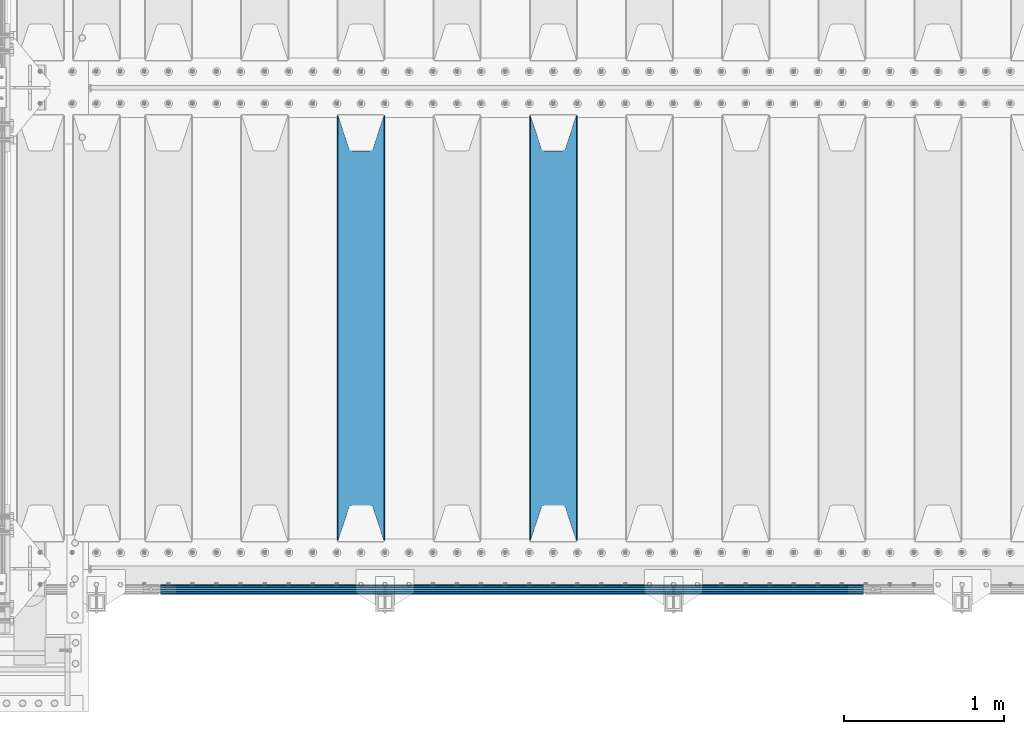
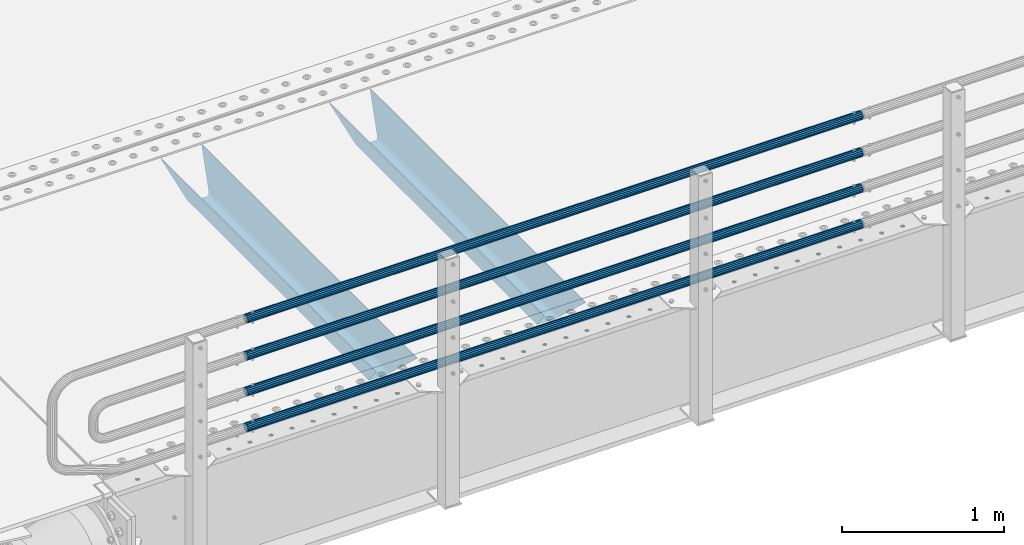
# One storey, part 116 of 270: 6 beams.
"""IFC2X3 building model written with IfcOpenShell, lengths in millimetres."""

from ifc_helpers import new_model, si_unit, frame, origin_with_axes, place, context, subcontext, project, spatial, faceted_brep, material, type_object, element, save


model = new_model("IFC2X3")

# Units and contexts
model_context = context("Model", 3, precision=1e-05, world=origin_with_axes())
body_context = subcontext(model_context, "Body", "Model", "MODEL_VIEW")
ifc_project = project(units=[si_unit("LENGTHUNIT", "METRE", prefix="MILLI"), si_unit("AREAUNIT", "SQUARE_METRE"), si_unit("VOLUMEUNIT", "CUBIC_METRE"), si_unit("MASSUNIT", "GRAM", prefix="KILO"), si_unit("TIMEUNIT", "SECOND"), si_unit("PLANEANGLEUNIT", "RADIAN"), si_unit("SOLIDANGLEUNIT", "STERADIAN"), si_unit("THERMODYNAMICTEMPERATUREUNIT", "DEGREE_CELSIUS"), si_unit("LUMINOUSINTENSITYUNIT", "LUMEN")], contexts=[model_context])

# Site, building, storey
site_placement = place(None, origin_with_axes())
site = spatial("IfcSite", under=ifc_project, at=site_placement, CompositionType="ELEMENT")
building_placement = place(site_placement, origin_with_axes())
building = spatial("IfcBuilding", under=site, at=building_placement, Name="Standard", CompositionType="ELEMENT")
storey_placement = place(building_placement, origin_with_axes())
storey = spatial("IfcBuildingStorey", under=building, at=storey_placement, Name="Undefined", CompositionType="ELEMENT", Elevation=0.0)

# Beams
ifc_material_1 = material()
beam_type_1 = type_object("IfcBeamType", PredefinedType="NOTDEFINED")
beam_1_placement = place(storey_placement, frame((5333.99999999987, -24129.8499999999, 149.849999999726), z_axis=(0.0, 0.0, -1.0), x_axis=(-1.0, 0.0, 0.0)))
element("IfcBeam", 1, at=beam_1_placement, inside=storey, type_object=beam_type_1, material=ifc_material_1, context=body_context, shape_type="Brep", body=[
    faceted_brep([(0.0, -26.5499999999993, 0.0), (0.0, -24.5290015881747, 10.1602451292931), (4384.00249699992, -24.5290015881747, 10.1602451292931), (4384.00249699992, -26.5499999999993, 0.0), (0.0, -18.7736850405036, 18.7736850405028), (4384.00249699992, -18.7736850405036, 18.7736850405028), (0.0, -10.1602451292929, 24.5290015881747), (4384.00249699992, -10.1602451292929, 24.5290015881747), (0.0, 0.0, 26.55), (4384.00249699992, 0.0, 26.55), (0.0, 10.1602451292929, 24.5290015881747), (4384.00249699992, 10.1602451292929, 24.5290015881747), (0.0, 18.7736850405036, 18.7736850405028), (4384.00249699992, 18.7736850405036, 18.7736850405028), (0.0, 24.5290015881747, 10.1602451292931), (4384.00249699992, 24.5290015881747, 10.1602451292931), (0.0, 26.5499999999993, 0.0), (4384.00249699992, 26.5499999999993, 0.0), (0.0, 24.5290015881747, -10.1602451292931), (4384.00249699992, 24.5290015881747, -10.1602451292931), (0.0, 18.7736850405036, -18.7736850405028), (4384.00249699992, 18.7736850405036, -18.7736850405028), (0.0, 10.1602451292929, -24.5290015881747), (4384.00249699992, 10.1602451292929, -24.5290015881747), (0.0, 0.0, -26.55), (4384.00249699992, 0.0, -26.55), (0.0, -10.1602451292929, -24.5290015881747), (4384.00249699992, -10.1602451292929, -24.5290015881747), (0.0, -18.7736850405036, -18.7736850405028), (4384.00249699992, -18.7736850405036, -18.7736850405028), (0.0, -24.5290015881747, -10.1602451292931), (4384.00249699992, -24.5290015881747, -10.1602451292931), (0.0, -30.1499999999996, 0.0), (0.0, -27.8549679052157, -11.5379054858058), (4384.00249699992, -27.8549679052157, -11.5379054858075), (4384.00249699992, -30.1499999999996, 0.0), (0.0, -21.3192694527752, -21.3192694527752), (4384.00249699992, -21.3192694527752, -21.3192694527744), (0.0, -11.5379054858076, -27.8549679052157), (4384.00249699992, -11.5379054858076, -27.8549679052153), (0.0, 0.0, -30.1500000000015), (4384.00249699992, 0.0, -30.15), (0.0, 11.5379054858076, -27.8549679052157), (4384.00249699992, 11.5379054858076, -27.8549679052153), (0.0, 21.3192694527752, -21.3192694527752), (4384.00249699992, 21.3192694527752, -21.3192694527744), (0.0, 27.8549679052157, -11.5379054858058), (4384.00249699992, 27.8549679052157, -11.5379054858074), (0.0, 30.1499999999996, 0.0), (4384.00249699992, 30.1499999999996, 0.0), (0.0, 27.8549679052157, 11.5379054858058), (4384.00249699992, 27.8549679052157, 11.5379054858075), (0.0, 21.3192694527752, 21.3192694527752), (4384.00249699992, 21.3192694527752, 21.3192694527744), (0.0, 11.5379054858076, 27.8549679052157), (4384.00249699992, 11.5379054858076, 27.8549679052153), (0.0, 0.0, 30.1500000000015), (4384.00249699992, 0.0, 30.15), (0.0, -11.5379054858076, 27.8549679052157), (4384.00249699992, -11.5379054858076, 27.8549679052153), (0.0, -21.3192694527752, 21.3192694527752), (4384.00249699992, -21.3192694527752, 21.3192694527744), (0.0, -27.8549679052157, 11.5379054858058), (4384.00249699992, -27.8549679052157, 11.5379054858075)], [[[0, 1, 2, 3]], [[1, 4, 5, 2]], [[4, 6, 7, 5]], [[6, 8, 9, 7]], [[8, 10, 11, 9]], [[10, 12, 13, 11]], [[12, 14, 15, 13]], [[14, 16, 17, 15]], [[16, 18, 19, 17]], [[18, 20, 21, 19]], [[20, 22, 23, 21]], [[22, 24, 25, 23]], [[24, 26, 27, 25]], [[26, 28, 29, 27]], [[28, 30, 31, 29]], [[30, 0, 3, 31]], [[32, 33, 34, 35]], [[33, 36, 37, 34]], [[36, 38, 39, 37]], [[38, 40, 41, 39]], [[40, 42, 43, 41]], [[42, 44, 45, 43]], [[44, 46, 47, 45]], [[46, 48, 49, 47]], [[48, 50, 51, 49]], [[50, 52, 53, 51]], [[52, 54, 55, 53]], [[54, 56, 57, 55]], [[56, 58, 59, 57]], [[58, 60, 61, 59]], [[60, 62, 63, 61]], [[62, 32, 35, 63]], [[37, 39, 41, 43, 45, 47, 49, 51, 53, 55, 57, 59, 61, 63, 35, 34], [5, 7, 9, 11, 13, 15, 17, 19, 21, 23, 25, 27, 29, 31, 3, 2]], [[62, 60, 58, 56, 54, 52, 50, 48, 46, 44, 42, 40, 38, 36, 33, 32], [30, 28, 26, 24, 22, 20, 18, 16, 14, 12, 10, 8, 6, 4, 1, 0]]]),
])
beam_2_placement = place(storey_placement, frame((5333.99999999987, -24129.8499999999, 420.149999999729), z_axis=(0.0, 0.0, -1.0), x_axis=(-1.0, 0.0, 0.0)))
element("IfcBeam", 2, at=beam_2_placement, inside=storey, type_object=beam_type_1, material=ifc_material_1, context=body_context, shape_type="Brep", body=[
    faceted_brep([(0.0, -26.5499999999993, 0.0), (0.0, -24.5290015881747, 10.1602451292931), (4384.00249699992, -24.5290015881747, 10.1602451292931), (4384.00249699992, -26.5499999999993, 0.0), (0.0, -18.7736850405036, 18.7736850405028), (4384.00249699992, -18.7736850405036, 18.7736850405028), (0.0, -10.1602451292929, 24.5290015881747), (4384.00249699992, -10.1602451292929, 24.5290015881747), (0.0, 0.0, 26.55), (4384.00249699992, 0.0, 26.55), (0.0, 10.1602451292929, 24.5290015881747), (4384.00249699992, 10.1602451292929, 24.5290015881747), (0.0, 18.7736850405036, 18.7736850405028), (4384.00249699992, 18.7736850405036, 18.7736850405028), (0.0, 24.5290015881747, 10.1602451292931), (4384.00249699992, 24.5290015881747, 10.1602451292931), (0.0, 26.5499999999993, 0.0), (4384.00249699992, 26.5499999999993, 0.0), (0.0, 24.5290015881747, -10.1602451292931), (4384.00249699992, 24.5290015881747, -10.1602451292931), (0.0, 18.7736850405036, -18.7736850405028), (4384.00249699992, 18.7736850405036, -18.7736850405028), (0.0, 10.1602451292929, -24.5290015881747), (4384.00249699992, 10.1602451292929, -24.5290015881747), (0.0, 0.0, -26.55), (4384.00249699992, 0.0, -26.55), (0.0, -10.1602451292929, -24.5290015881747), (4384.00249699992, -10.1602451292929, -24.5290015881747), (0.0, -18.7736850405036, -18.7736850405028), (4384.00249699992, -18.7736850405036, -18.7736850405028), (0.0, -24.5290015881747, -10.1602451292931), (4384.00249699992, -24.5290015881747, -10.1602451292931), (0.0, -30.1499999999996, 0.0), (0.0, -27.8549679052157, -11.5379054858058), (4384.00249699992, -27.8549679052157, -11.5379054858075), (4384.00249699992, -30.1499999999996, 0.0), (0.0, -21.3192694527752, -21.3192694527752), (4384.00249699992, -21.3192694527752, -21.3192694527744), (0.0, -11.5379054858076, -27.8549679052157), (4384.00249699992, -11.5379054858076, -27.8549679052153), (0.0, 0.0, -30.1500000000015), (4384.00249699992, 0.0, -30.15), (0.0, 11.5379054858076, -27.8549679052157), (4384.00249699992, 11.5379054858076, -27.8549679052153), (0.0, 21.3192694527752, -21.3192694527752), (4384.00249699992, 21.3192694527752, -21.3192694527744), (0.0, 27.8549679052157, -11.5379054858058), (4384.00249699992, 27.8549679052157, -11.5379054858074), (0.0, 30.1499999999996, 0.0), (4384.00249699992, 30.1499999999996, 0.0), (0.0, 27.8549679052157, 11.5379054858058), (4384.00249699992, 27.8549679052157, 11.5379054858075), (0.0, 21.3192694527752, 21.3192694527752), (4384.00249699992, 21.3192694527752, 21.3192694527744), (0.0, 11.5379054858076, 27.8549679052157), (4384.00249699992, 11.5379054858076, 27.8549679052153), (0.0, 0.0, 30.1500000000015), (4384.00249699992, 0.0, 30.15), (0.0, -11.5379054858076, 27.8549679052157), (4384.00249699992, -11.5379054858076, 27.8549679052153), (0.0, -21.3192694527752, 21.3192694527752), (4384.00249699992, -21.3192694527752, 21.3192694527744), (0.0, -27.8549679052157, 11.5379054858058), (4384.00249699992, -27.8549679052157, 11.5379054858075)], [[[0, 1, 2, 3]], [[1, 4, 5, 2]], [[4, 6, 7, 5]], [[6, 8, 9, 7]], [[8, 10, 11, 9]], [[10, 12, 13, 11]], [[12, 14, 15, 13]], [[14, 16, 17, 15]], [[16, 18, 19, 17]], [[18, 20, 21, 19]], [[20, 22, 23, 21]], [[22, 24, 25, 23]], [[24, 26, 27, 25]], [[26, 28, 29, 27]], [[28, 30, 31, 29]], [[30, 0, 3, 31]], [[32, 33, 34, 35]], [[33, 36, 37, 34]], [[36, 38, 39, 37]], [[38, 40, 41, 39]], [[40, 42, 43, 41]], [[42, 44, 45, 43]], [[44, 46, 47, 45]], [[46, 48, 49, 47]], [[48, 50, 51, 49]], [[50, 52, 53, 51]], [[52, 54, 55, 53]], [[54, 56, 57, 55]], [[56, 58, 59, 57]], [[58, 60, 61, 59]], [[60, 62, 63, 61]], [[62, 32, 35, 63]], [[37, 39, 41, 43, 45, 47, 49, 51, 53, 55, 57, 59, 61, 63, 35, 34], [5, 7, 9, 11, 13, 15, 17, 19, 21, 23, 25, 27, 29, 31, 3, 2]], [[62, 60, 58, 56, 54, 52, 50, 48, 46, 44, 42, 40, 38, 36, 33, 32], [30, 28, 26, 24, 22, 20, 18, 16, 14, 12, 10, 8, 6, 4, 1, 0]]]),
])
beam_3_placement = place(storey_placement, frame((5333.99999999987, -24129.8499999999, 969.849999999726), z_axis=(0.0, 0.0, -1.0), x_axis=(-1.0, 0.0, 0.0)))
element("IfcBeam", 3, at=beam_3_placement, inside=storey, type_object=beam_type_1, material=ifc_material_1, context=body_context, shape_type="Brep", body=[
    faceted_brep([(0.0, -26.5499999999993, 0.0), (0.0, -24.5290015881747, 10.1602451292931), (4384.00249699992, -24.5290015881747, 10.1602451292931), (4384.00249699992, -26.5499999999993, 0.0), (0.0, -18.7736850405036, 18.7736850405028), (4384.00249699992, -18.7736850405036, 18.7736850405028), (0.0, -10.1602451292929, 24.5290015881747), (4384.00249699992, -10.1602451292929, 24.5290015881747), (0.0, 0.0, 26.55), (4384.00249699992, 0.0, 26.55), (0.0, 10.1602451292929, 24.5290015881747), (4384.00249699992, 10.1602451292929, 24.5290015881747), (0.0, 18.7736850405036, 18.7736850405028), (4384.00249699992, 18.7736850405036, 18.7736850405028), (0.0, 24.5290015881747, 10.1602451292931), (4384.00249699992, 24.5290015881747, 10.1602451292931), (0.0, 26.5499999999993, 0.0), (4384.00249699992, 26.5499999999993, 0.0), (0.0, 24.5290015881747, -10.1602451292931), (4384.00249699992, 24.5290015881747, -10.1602451292931), (0.0, 18.7736850405036, -18.7736850405028), (4384.00249699992, 18.7736850405036, -18.7736850405028), (0.0, 10.1602451292929, -24.5290015881747), (4384.00249699992, 10.1602451292929, -24.5290015881747), (0.0, 0.0, -26.55), (4384.00249699992, 0.0, -26.55), (0.0, -10.1602451292929, -24.5290015881747), (4384.00249699992, -10.1602451292929, -24.5290015881747), (0.0, -18.7736850405036, -18.7736850405028), (4384.00249699992, -18.7736850405036, -18.7736850405028), (0.0, -24.5290015881747, -10.1602451292931), (4384.00249699992, -24.5290015881747, -10.1602451292931), (0.0, -30.1499999999996, 0.0), (0.0, -27.8549679052157, -11.5379054858058), (4384.00249699992, -27.8549679052157, -11.5379054858075), (4384.00249699992, -30.1499999999996, 0.0), (0.0, -21.3192694527752, -21.3192694527752), (4384.00249699992, -21.3192694527752, -21.3192694527744), (0.0, -11.5379054858076, -27.8549679052157), (4384.00249699992, -11.5379054858076, -27.8549679052153), (0.0, 0.0, -30.1500000000015), (4384.00249699992, 0.0, -30.15), (0.0, 11.5379054858076, -27.8549679052157), (4384.00249699992, 11.5379054858076, -27.8549679052153), (0.0, 21.3192694527752, -21.3192694527752), (4384.00249699992, 21.3192694527752, -21.3192694527744), (0.0, 27.8549679052157, -11.5379054858058), (4384.00249699992, 27.8549679052157, -11.5379054858074), (0.0, 30.1499999999996, 0.0), (4384.00249699992, 30.1499999999996, 0.0), (0.0, 27.8549679052157, 11.5379054858058), (4384.00249699992, 27.8549679052157, 11.5379054858075), (0.0, 21.3192694527752, 21.3192694527752), (4384.00249699992, 21.3192694527752, 21.3192694527744), (0.0, 11.5379054858076, 27.8549679052157), (4384.00249699992, 11.5379054858076, 27.8549679052153), (0.0, 0.0, 30.1500000000015), (4384.00249699992, 0.0, 30.15), (0.0, -11.5379054858076, 27.8549679052157), (4384.00249699992, -11.5379054858076, 27.8549679052153), (0.0, -21.3192694527752, 21.3192694527752), (4384.00249699992, -21.3192694527752, 21.3192694527744), (0.0, -27.8549679052157, 11.5379054858058), (4384.00249699992, -27.8549679052157, 11.5379054858075)], [[[0, 1, 2, 3]], [[1, 4, 5, 2]], [[4, 6, 7, 5]], [[6, 8, 9, 7]], [[8, 10, 11, 9]], [[10, 12, 13, 11]], [[12, 14, 15, 13]], [[14, 16, 17, 15]], [[16, 18, 19, 17]], [[18, 20, 21, 19]], [[20, 22, 23, 21]], [[22, 24, 25, 23]], [[24, 26, 27, 25]], [[26, 28, 29, 27]], [[28, 30, 31, 29]], [[30, 0, 3, 31]], [[32, 33, 34, 35]], [[33, 36, 37, 34]], [[36, 38, 39, 37]], [[38, 40, 41, 39]], [[40, 42, 43, 41]], [[42, 44, 45, 43]], [[44, 46, 47, 45]], [[46, 48, 49, 47]], [[48, 50, 51, 49]], [[50, 52, 53, 51]], [[52, 54, 55, 53]], [[54, 56, 57, 55]], [[56, 58, 59, 57]], [[58, 60, 61, 59]], [[60, 62, 63, 61]], [[62, 32, 35, 63]], [[37, 39, 41, 43, 45, 47, 49, 51, 53, 55, 57, 59, 61, 63, 35, 34], [5, 7, 9, 11, 13, 15, 17, 19, 21, 23, 25, 27, 29, 31, 3, 2]], [[62, 60, 58, 56, 54, 52, 50, 48, 46, 44, 42, 40, 38, 36, 33, 32], [30, 28, 26, 24, 22, 20, 18, 16, 14, 12, 10, 8, 6, 4, 1, 0]]]),
])
beam_4_placement = place(storey_placement, frame((5333.99999999987, -24129.8499999999, 689.849999999726), z_axis=(0.0, 0.0, -1.0), x_axis=(-1.0, 0.0, 0.0)))
element("IfcBeam", 4, at=beam_4_placement, inside=storey, type_object=beam_type_1, material=ifc_material_1, context=body_context, shape_type="Brep", body=[
    faceted_brep([(0.0, -26.5499999999993, 0.0), (0.0, -24.5290015881747, 10.1602451292931), (4384.00249699992, -24.5290015881747, 10.1602451292931), (4384.00249699992, -26.5499999999993, 0.0), (0.0, -18.7736850405036, 18.7736850405028), (4384.00249699992, -18.7736850405036, 18.7736850405028), (0.0, -10.1602451292929, 24.5290015881747), (4384.00249699992, -10.1602451292929, 24.5290015881747), (0.0, 0.0, 26.55), (4384.00249699992, 0.0, 26.55), (0.0, 10.1602451292929, 24.5290015881747), (4384.00249699992, 10.1602451292929, 24.5290015881747), (0.0, 18.7736850405036, 18.7736850405028), (4384.00249699992, 18.7736850405036, 18.7736850405028), (0.0, 24.5290015881747, 10.1602451292931), (4384.00249699992, 24.5290015881747, 10.1602451292931), (0.0, 26.5499999999993, 0.0), (4384.00249699992, 26.5499999999993, 0.0), (0.0, 24.5290015881747, -10.1602451292931), (4384.00249699992, 24.5290015881747, -10.1602451292931), (0.0, 18.7736850405036, -18.7736850405028), (4384.00249699992, 18.7736850405036, -18.7736850405028), (0.0, 10.1602451292929, -24.5290015881747), (4384.00249699992, 10.1602451292929, -24.5290015881747), (0.0, 0.0, -26.55), (4384.00249699992, 0.0, -26.55), (0.0, -10.1602451292929, -24.5290015881747), (4384.00249699992, -10.1602451292929, -24.5290015881747), (0.0, -18.7736850405036, -18.7736850405028), (4384.00249699992, -18.7736850405036, -18.7736850405028), (0.0, -24.5290015881747, -10.1602451292931), (4384.00249699992, -24.5290015881747, -10.1602451292931), (0.0, -30.1499999999996, 0.0), (0.0, -27.8549679052157, -11.5379054858058), (4384.00249699992, -27.8549679052157, -11.5379054858075), (4384.00249699992, -30.1499999999996, 0.0), (0.0, -21.3192694527752, -21.3192694527752), (4384.00249699992, -21.3192694527752, -21.3192694527744), (0.0, -11.5379054858076, -27.8549679052157), (4384.00249699992, -11.5379054858076, -27.8549679052153), (0.0, 0.0, -30.1500000000015), (4384.00249699992, 0.0, -30.15), (0.0, 11.5379054858076, -27.8549679052157), (4384.00249699992, 11.5379054858076, -27.8549679052153), (0.0, 21.3192694527752, -21.3192694527752), (4384.00249699992, 21.3192694527752, -21.3192694527744), (0.0, 27.8549679052157, -11.5379054858058), (4384.00249699992, 27.8549679052157, -11.5379054858074), (0.0, 30.1499999999996, 0.0), (4384.00249699992, 30.1499999999996, 0.0), (0.0, 27.8549679052157, 11.5379054858058), (4384.00249699992, 27.8549679052157, 11.5379054858075), (0.0, 21.3192694527752, 21.3192694527752), (4384.00249699992, 21.3192694527752, 21.3192694527744), (0.0, 11.5379054858076, 27.8549679052157), (4384.00249699992, 11.5379054858076, 27.8549679052153), (0.0, 0.0, 30.1500000000015), (4384.00249699992, 0.0, 30.15), (0.0, -11.5379054858076, 27.8549679052157), (4384.00249699992, -11.5379054858076, 27.8549679052153), (0.0, -21.3192694527752, 21.3192694527752), (4384.00249699992, -21.3192694527752, 21.3192694527744), (0.0, -27.8549679052157, 11.5379054858058), (4384.00249699992, -27.8549679052157, 11.5379054858075)], [[[0, 1, 2, 3]], [[1, 4, 5, 2]], [[4, 6, 7, 5]], [[6, 8, 9, 7]], [[8, 10, 11, 9]], [[10, 12, 13, 11]], [[12, 14, 15, 13]], [[14, 16, 17, 15]], [[16, 18, 19, 17]], [[18, 20, 21, 19]], [[20, 22, 23, 21]], [[22, 24, 25, 23]], [[24, 26, 27, 25]], [[26, 28, 29, 27]], [[28, 30, 31, 29]], [[30, 0, 3, 31]], [[32, 33, 34, 35]], [[33, 36, 37, 34]], [[36, 38, 39, 37]], [[38, 40, 41, 39]], [[40, 42, 43, 41]], [[42, 44, 45, 43]], [[44, 46, 47, 45]], [[46, 48, 49, 47]], [[48, 50, 51, 49]], [[50, 52, 53, 51]], [[52, 54, 55, 53]], [[54, 56, 57, 55]], [[56, 58, 59, 57]], [[58, 60, 61, 59]], [[60, 62, 63, 61]], [[62, 32, 35, 63]], [[37, 39, 41, 43, 45, 47, 49, 51, 53, 55, 57, 59, 61, 63, 35, 34], [5, 7, 9, 11, 13, 15, 17, 19, 21, 23, 25, 27, 29, 31, 3, 2]], [[62, 60, 58, 56, 54, 52, 50, 48, 46, 44, 42, 40, 38, 36, 33, 32], [30, 28, 26, 24, 22, 20, 18, 16, 14, 12, 10, 8, 6, 4, 1, 0]]]),
])
ifc_material_2 = material(Name="STEEL/S355N")
beam_type_2 = type_object("IfcBeamType", PredefinedType="NOTDEFINED")
beam_5_placement = place(storey_placement, frame((3400.0, -23825.0, -115.0), z_axis=(0.0, 0.0, 1.0), x_axis=(0.0, 1.0, 0.0)))
element("IfcBeam", 5, at=beam_5_placement, inside=storey, type_object=beam_type_2, material=ifc_material_2, context=body_context, shape_type="Brep", body=[
    faceted_brep([(0.0, 150.0, 115.0), (0.0, 143.689999999999, 115.0), (2650.00000000297, 143.689999999999, 115.0), (2650.00000000297, 150.0, 115.0), (2650.00000000297, 142.059565218398, 110.000000003096), (2650.00000000297, 148.3695652184, 110.000000003096), (2441.90079219209, -80.1103600731112, -98.0992078077845), (2437.7588105432, -77.5672621345584, -102.241189456673), (2434.06523489747, -74.4080125315522, -105.934765102404), (2430.9108609509, -70.710272125576, -109.089139048974), (2428.37322971128, -66.5649389910068, -111.626770288588), (2426.51472138055, -62.0739139532889, -113.485278619323), (2425.38102192092, -57.3475956567672, -114.618978078955), (2424.99999999987, -52.5021667386536, -115.0), (2424.99999999987, 52.5021667386536, -115.0), (2425.38102192092, 57.3475956567672, -114.618978078955), (2426.51472138055, 62.0739139532889, -113.485278619323), (2428.37322971128, 66.5649389910068, -111.626770288588), (2430.9108609509, 70.710272125576, -109.089139048974), (2434.06523489747, 74.4080125315522, -105.934765102404), (2437.7588105432, 77.5672621345584, -102.241189456673), (2441.90079219209, 80.1103600731112, -98.0992078077846), (2446.38936140511, 81.9747917625791, -93.6106385947584), (2448.2494850041, 76.2713538057251, -91.7505149957729), (2444.62967112263, 74.76777986261, -95.3703288772456), (2441.28936334126, 72.7168944282894, -98.710636658607), (2438.31067330439, 70.1691124903846, -101.689326695487), (2435.76682334747, 67.1870637758839, -104.233176652398), (2433.72034654133, 63.8440531834895, -106.279653458539), (2432.22154950042, 60.222258798236, -107.778450499454), (2431.30727574265, 56.4107117849089, -108.692724257221), (2430.99999999987, 52.5031078186876, -109.0), (2430.99999999987, -52.5031078186876, -109.0), (2431.30727574265, -56.4107117849089, -108.692724257221), (2432.22154950042, -60.222258798236, -107.778450499454), (2433.72034654133, -63.8440531834895, -106.279653458539), (2435.76682334747, -67.1870637758839, -104.233176652398), (2438.31067330438, -70.1691124903846, -101.689326695487), (2441.28936334126, -72.7168944282894, -98.7106366586071), (2444.62967112263, -74.76777986261, -95.3703288772457), (2448.2494850041, -76.2713538057251, -91.7505149957729), (2650.00000000297, -142.059565218398, 110.000000003096), (2650.00000000297, -148.3695652184, 110.000000003096), (2446.38936140511, -81.9747917625791, -93.6106385947584), (2650.00000000297, -143.689999999999, 115.0), (2650.00000000297, -150.0, 115.0), (0.0, -143.689999999999, 115.0), (0.0, -150.0, 115.0), (0.0, -148.369565218261, 110.000000002672), (203.610638597431, -81.9747917625791, -93.6106385947584), (208.099207810457, -80.1103600731112, -98.0992078077845), (212.241189459342, -77.5672621345584, -102.241189456673), (215.934765105078, -74.4080125315522, -105.934765102404), (219.089139051644, -70.710272125576, -109.089139048974), (221.626770291259, -66.5649389910068, -111.626770288588), (223.485278621993, -62.0739139532889, -113.485278619323), (224.618978081628, -57.3475956567672, -114.618978078955), (225.00000000267, -52.5021667386536, -115.0), (225.00000000267, 52.5021667386536, -115.0), (224.618978081628, 57.3475956567672, -114.618978078955), (223.485278621993, 62.0739139532889, -113.485278619323), (221.626770291259, 66.5649389910068, -111.626770288588), (219.089139051644, 70.710272125576, -109.089139048974), (215.934765105078, 74.4080125315522, -105.934765102404), (212.241189459342, 77.5672621345584, -102.241189456673), (208.099207810457, 80.1103600731112, -98.0992078077846), (203.610638597431, 81.9747917625791, -93.6106385947584), (0.0, 148.369565218261, 110.000000002672), (0.0, 142.05956521826, 110.000000002672), (201.750514998446, 76.2713538057251, -91.7505149957729), (205.370328879915, 74.76777986261, -95.3703288772456), (208.710636661279, 72.7168944282894, -98.710636658607), (211.689326698157, 70.1691124903846, -101.689326695487), (214.233176655071, 67.1870637758839, -104.233176652398), (216.27965346121, 63.8440531834895, -106.279653458539), (217.778450502126, 60.222258798236, -107.778450499454), (218.692724259894, 56.4107117849089, -108.692724257221), (219.00000000267, 52.5031078186876, -109.0), (219.00000000267, -52.5031078186876, -109.0), (218.692724259894, -56.4107117849089, -108.692724257221), (217.778450502123, -60.222258798236, -107.778450499454), (216.27965346121, -63.8440531834895, -106.279653458539), (214.233176655071, -67.1870637758839, -104.233176652398), (211.689326698157, -70.1691124903846, -101.689326695487), (208.710636661279, -72.7168944282894, -98.7106366586071), (205.370328879915, -74.76777986261, -95.3703288772457), (201.750514998446, -76.2713538057251, -91.7505149957729), (0.0, -142.05956521826, 110.000000002672)], [[[0, 1, 2, 3]], [[3, 2, 4, 5]], [[6, 7, 8, 9, 10, 11, 12, 13, 14, 15, 16, 17, 18, 19, 20, 21, 22, 5, 4, 23, 24, 25, 26, 27, 28, 29, 30, 31, 32, 33, 34, 35, 36, 37, 38, 39, 40, 41, 42, 43]], [[44, 45, 42, 41]], [[46, 47, 45, 44]], [[43, 42, 45, 47, 48, 49]], [[6, 43, 49, 50]], [[7, 6, 50, 51]], [[8, 7, 51, 52]], [[9, 8, 52, 53]], [[10, 9, 53, 54]], [[11, 10, 54, 55]], [[12, 11, 55, 56]], [[13, 12, 56, 57]], [[14, 13, 57, 58]], [[15, 14, 58, 59]], [[16, 15, 59, 60]], [[17, 16, 60, 61]], [[18, 17, 61, 62]], [[19, 18, 62, 63]], [[20, 19, 63, 64]], [[21, 20, 64, 65]], [[22, 21, 65, 66]], [[0, 3, 5, 22, 66, 67]], [[1, 0, 67, 68]], [[23, 4, 2, 1, 68, 69]], [[24, 23, 69, 70]], [[25, 24, 70, 71]], [[26, 25, 71, 72]], [[27, 26, 72, 73]], [[28, 27, 73, 74]], [[29, 28, 74, 75]], [[30, 29, 75, 76]], [[31, 30, 76, 77]], [[32, 31, 77, 78]], [[33, 32, 78, 79]], [[34, 33, 79, 80]], [[35, 34, 80, 81]], [[36, 35, 81, 82]], [[37, 36, 82, 83]], [[38, 37, 83, 84]], [[39, 38, 84, 85]], [[40, 39, 85, 86]], [[46, 44, 41, 40, 86, 87]], [[47, 46, 87, 48]], [[86, 85, 84, 83, 82, 81, 80, 79, 78, 77, 76, 75, 74, 73, 72, 71, 70, 69, 68, 67, 66, 65, 64, 63, 62, 61, 60, 59, 58, 57, 56, 55, 54, 53, 52, 51, 50, 49, 48, 87]]]),
])
beam_6_placement = place(storey_placement, frame((2200.0, -23825.0, -115.0), z_axis=(0.0, 0.0, 1.0), x_axis=(0.0, 1.0, 0.0)))
element("IfcBeam", 6, at=beam_6_placement, inside=storey, type_object=beam_type_2, material=ifc_material_2, context=body_context, shape_type="Brep", body=[
    faceted_brep([(0.0, 150.0, 115.0), (0.0, 143.689999999999, 115.0), (2650.00000000297, 143.689999999999, 115.0), (2650.00000000297, 150.0, 115.0), (2650.00000000297, 142.059565218398, 110.000000003096), (2650.00000000297, 148.3695652184, 110.000000003096), (2441.90079219209, -80.1103600731112, -98.0992078077845), (2437.7588105432, -77.5672621345584, -102.241189456673), (2434.06523489747, -74.4080125315522, -105.934765102404), (2430.9108609509, -70.710272125576, -109.089139048974), (2428.37322971128, -66.5649389910068, -111.626770288588), (2426.51472138055, -62.0739139532889, -113.485278619323), (2425.38102192092, -57.3475956567672, -114.618978078955), (2424.99999999987, -52.5021667386536, -115.0), (2424.99999999987, 52.5021667386536, -115.0), (2425.38102192092, 57.3475956567672, -114.618978078955), (2426.51472138055, 62.0739139532889, -113.485278619323), (2428.37322971128, 66.5649389910068, -111.626770288588), (2430.9108609509, 70.710272125576, -109.089139048974), (2434.06523489747, 74.4080125315522, -105.934765102404), (2437.7588105432, 77.5672621345584, -102.241189456673), (2441.90079219209, 80.1103600731112, -98.0992078077846), (2446.38936140511, 81.9747917625791, -93.6106385947584), (2448.2494850041, 76.2713538057251, -91.7505149957729), (2444.62967112263, 74.76777986261, -95.3703288772456), (2441.28936334126, 72.7168944282894, -98.710636658607), (2438.31067330439, 70.1691124903846, -101.689326695487), (2435.76682334747, 67.1870637758839, -104.233176652398), (2433.72034654133, 63.8440531834895, -106.279653458539), (2432.22154950042, 60.222258798236, -107.778450499454), (2431.30727574265, 56.4107117849089, -108.692724257221), (2430.99999999987, 52.5031078186876, -109.0), (2430.99999999987, -52.5031078186876, -109.0), (2431.30727574265, -56.4107117849089, -108.692724257221), (2432.22154950042, -60.222258798236, -107.778450499454), (2433.72034654133, -63.8440531834895, -106.279653458539), (2435.76682334747, -67.1870637758839, -104.233176652398), (2438.31067330438, -70.1691124903846, -101.689326695487), (2441.28936334126, -72.7168944282894, -98.7106366586071), (2444.62967112263, -74.76777986261, -95.3703288772457), (2448.2494850041, -76.2713538057251, -91.7505149957729), (2650.00000000297, -142.059565218398, 110.000000003096), (2650.00000000297, -148.3695652184, 110.000000003096), (2446.38936140511, -81.9747917625791, -93.6106385947584), (2650.00000000297, -143.689999999999, 115.0), (2650.00000000297, -150.0, 115.0), (0.0, -143.689999999999, 115.0), (0.0, -150.0, 115.0), (0.0, -148.369565218261, 110.000000002672), (203.610638597431, -81.9747917625791, -93.6106385947584), (208.099207810457, -80.1103600731112, -98.0992078077845), (212.241189459342, -77.5672621345584, -102.241189456673), (215.934765105078, -74.4080125315522, -105.934765102404), (219.089139051644, -70.710272125576, -109.089139048974), (221.626770291259, -66.5649389910068, -111.626770288588), (223.485278621993, -62.0739139532889, -113.485278619323), (224.618978081628, -57.3475956567672, -114.618978078955), (225.00000000267, -52.5021667386536, -115.0), (225.00000000267, 52.5021667386536, -115.0), (224.618978081628, 57.3475956567672, -114.618978078955), (223.485278621993, 62.0739139532889, -113.485278619323), (221.626770291259, 66.5649389910068, -111.626770288588), (219.089139051644, 70.710272125576, -109.089139048974), (215.934765105078, 74.4080125315522, -105.934765102404), (212.241189459342, 77.5672621345584, -102.241189456673), (208.099207810457, 80.1103600731112, -98.0992078077846), (203.610638597431, 81.9747917625791, -93.6106385947584), (0.0, 148.369565218261, 110.000000002672), (0.0, 142.05956521826, 110.000000002672), (201.750514998446, 76.2713538057251, -91.7505149957729), (205.370328879915, 74.76777986261, -95.3703288772456), (208.710636661279, 72.7168944282894, -98.710636658607), (211.689326698157, 70.1691124903846, -101.689326695487), (214.233176655071, 67.1870637758839, -104.233176652398), (216.27965346121, 63.8440531834895, -106.279653458539), (217.778450502126, 60.222258798236, -107.778450499454), (218.692724259894, 56.4107117849089, -108.692724257221), (219.00000000267, 52.5031078186876, -109.0), (219.00000000267, -52.5031078186876, -109.0), (218.692724259894, -56.4107117849089, -108.692724257221), (217.778450502123, -60.222258798236, -107.778450499454), (216.27965346121, -63.8440531834895, -106.279653458539), (214.233176655071, -67.1870637758839, -104.233176652398), (211.689326698157, -70.1691124903846, -101.689326695487), (208.710636661279, -72.7168944282894, -98.7106366586071), (205.370328879915, -74.76777986261, -95.3703288772457), (201.750514998446, -76.2713538057251, -91.7505149957729), (0.0, -142.05956521826, 110.000000002672)], [[[0, 1, 2, 3]], [[3, 2, 4, 5]], [[6, 7, 8, 9, 10, 11, 12, 13, 14, 15, 16, 17, 18, 19, 20, 21, 22, 5, 4, 23, 24, 25, 26, 27, 28, 29, 30, 31, 32, 33, 34, 35, 36, 37, 38, 39, 40, 41, 42, 43]], [[44, 45, 42, 41]], [[46, 47, 45, 44]], [[43, 42, 45, 47, 48, 49]], [[6, 43, 49, 50]], [[7, 6, 50, 51]], [[8, 7, 51, 52]], [[9, 8, 52, 53]], [[10, 9, 53, 54]], [[11, 10, 54, 55]], [[12, 11, 55, 56]], [[13, 12, 56, 57]], [[14, 13, 57, 58]], [[15, 14, 58, 59]], [[16, 15, 59, 60]], [[17, 16, 60, 61]], [[18, 17, 61, 62]], [[19, 18, 62, 63]], [[20, 19, 63, 64]], [[21, 20, 64, 65]], [[22, 21, 65, 66]], [[0, 3, 5, 22, 66, 67]], [[1, 0, 67, 68]], [[23, 4, 2, 1, 68, 69]], [[24, 23, 69, 70]], [[25, 24, 70, 71]], [[26, 25, 71, 72]], [[27, 26, 72, 73]], [[28, 27, 73, 74]], [[29, 28, 74, 75]], [[30, 29, 75, 76]], [[31, 30, 76, 77]], [[32, 31, 77, 78]], [[33, 32, 78, 79]], [[34, 33, 79, 80]], [[35, 34, 80, 81]], [[36, 35, 81, 82]], [[37, 36, 82, 83]], [[38, 37, 83, 84]], [[39, 38, 84, 85]], [[40, 39, 85, 86]], [[46, 44, 41, 40, 86, 87]], [[47, 46, 87, 48]], [[86, 85, 84, 83, 82, 81, 80, 79, 78, 77, 76, 75, 74, 73, 72, 71, 70, 69, 68, 67, 66, 65, 64, 63, 62, 61, 60, 59, 58, 57, 56, 55, 54, 53, 52, 51, 50, 49, 48, 87]]]),
])

save(model, "model.ifc")
